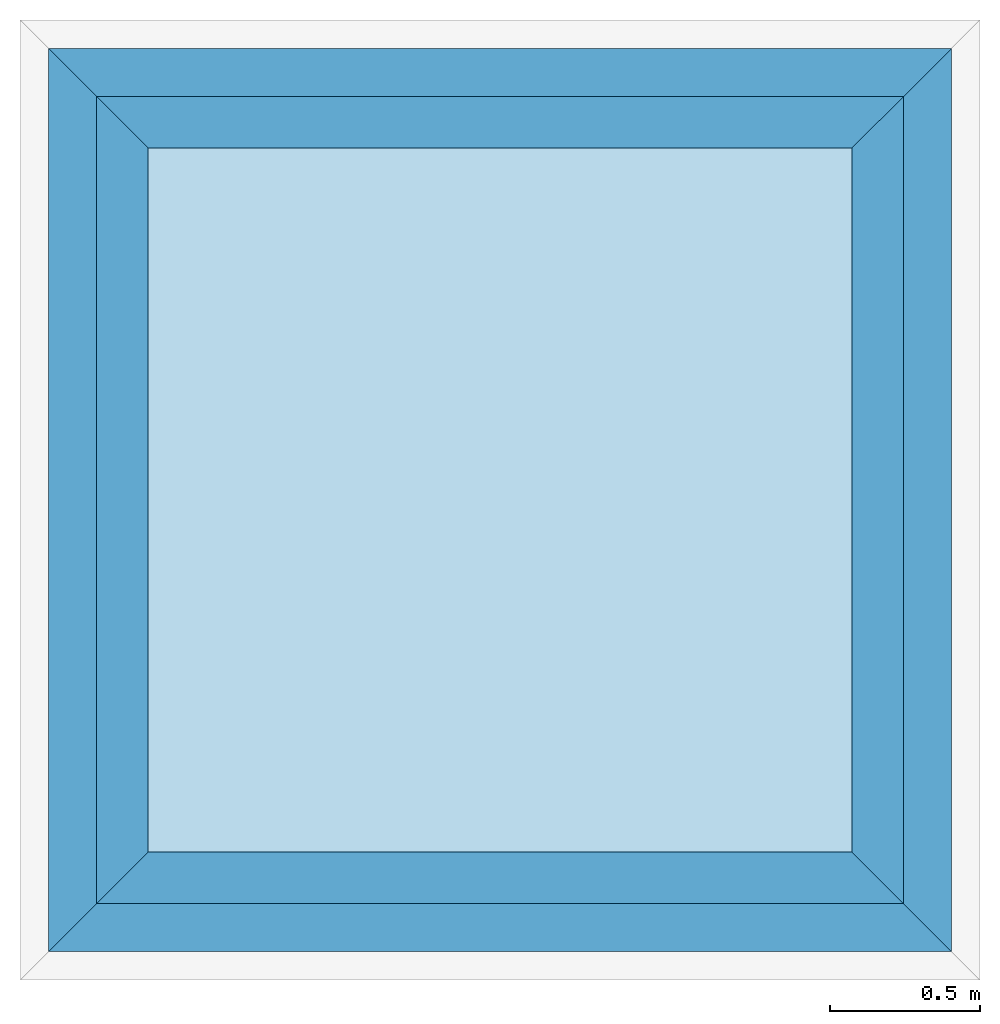
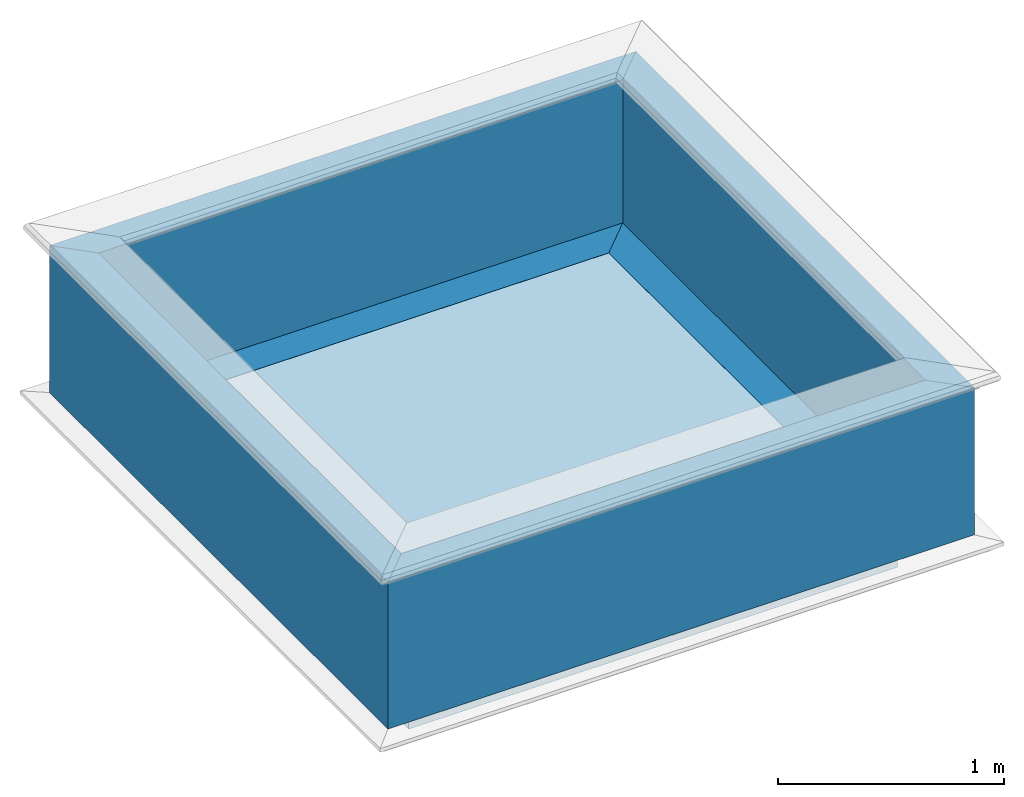
# One storey, part 1 of 2: 4 walls, 1 roof, 2 elements without a shape of their own.
"""IFC4 building model written with IfcOpenShell, lengths in metres."""

from ifc_helpers import new_model, si_unit, frame, origin, origin_with_axes, origin_2d_with_axis, place, context, subcontext, project, library, spatial, polyline, outline, extrude, clip, halfspace, material, layer, layer_set, layer_usage, material_profile, profile_set, profile_usage, type_object, element, aggregate, save


model = new_model("IFC4")

# Units and contexts
model_context = context("Model", 3, precision=1e-05, world=origin_with_axes())
plan_context = context("Plan", 2, precision=1e-05, world=origin_2d_with_axis())
body_context = subcontext(model_context, "Body", "Model", "MODEL_VIEW")
ifc_project = project(units=[si_unit("LENGTHUNIT", "METRE"), si_unit("AREAUNIT", "SQUARE_METRE"), si_unit("VOLUMEUNIT", "CUBIC_METRE"), si_unit("PLANEANGLEUNIT", "RADIAN")], contexts=[model_context, plan_context])
project_library = library(declared=ifc_project)

# Site, building, storey
site = spatial("IfcSite", under=ifc_project)
building = spatial("IfcBuilding", under=site, Name="Cube")
storey_placement = place(None, frame((0.0, 0.0, 2.5), z_axis=(0.0, 0.0, 1.0), x_axis=(1.0, 0.0, 0.0)))
storey = spatial("IfcBuildingStorey", under=building, at=storey_placement, Name="1", CompositionType="ELEMENT", Elevation=2.5)

# Assembly, walls
assembly_1_placement = place(storey_placement, frame((0.0, 0.0, -2.5), z_axis=(0.0, 0.0, 1.0), x_axis=(1.0, 0.0, 0.0)))
assembly_1 = element("IfcElementAssembly", 1, at=assembly_1_placement, inside=storey, Name="parapet")
ifc_material_1 = material(Name="Masonry")
ifc_material_profile = material_profile(ifc_material_1, outline(polyline([(0.25, 0.0), (0.25, 0.795), (0.09, 0.795), (0.09, 0.02), (-0.08, 0.02), (-0.08, 0.0), (0.25, 0.0)])))
ifc_profile_set = profile_set([ifc_material_profile])
ifc_profile_usage_1 = profile_usage(ifc_profile_set)
wall_type = type_object("IfcWallType", Name="parapet", PredefinedType="NOTDEFINED", material=ifc_profile_set)
wall_1_placement = place(assembly_1_placement, frame((-1.0, 2.5, 2.5), z_axis=(1.0, 0.0, 0.0), x_axis=(0.0, 1.0, 0.0)))
wall_1 = element("IfcWall", 2, at=wall_1_placement, type_object=wall_type, material=ifc_profile_usage_1, Name="parapet", context=body_context, shape_type="Clipping", body=[
    clip(clip(extrude(outline(polyline([(0.25, 0.0), (0.25, 0.795), (0.09, 0.795), (0.09, 0.02), (-0.08, 0.02), (-0.08, 0.0), (0.25, 0.0)])), origin_with_axes(), (0.0, 0.0, 1.0), 4.5), halfspace(frame((0.0, -2.5, 1.0), z_axis=(-0.707106781186547, 0.0, -0.707106781186547), x_axis=(0.707106781186547, 0.0, -0.707106781186547)), False)), halfspace(frame((0.0, -2.5, 3.5), z_axis=(-0.707106781186547, 0.0, 0.707106781186547), x_axis=(0.707106781186547, 0.0, 0.707106781186547)), False)),
])
ifc_profile_usage_2 = profile_usage(ifc_profile_set)
wall_2_placement = place(assembly_1_placement, frame((0.0, -1.0, 2.5), z_axis=(0.0, 1.0, 0.0), x_axis=(-1.0, 0.0, 0.0)))
wall_2 = element("IfcWall", 3, at=wall_2_placement, type_object=wall_type, material=ifc_profile_usage_2, Name="parapet", context=body_context, shape_type="Clipping", body=[
    clip(clip(extrude(outline(polyline([(0.25, 0.0), (0.25, 0.795), (0.09, 0.795), (0.09, 0.02), (-0.08, 0.02), (-0.08, 0.0), (0.25, 0.0)])), origin_with_axes(), (0.0, 0.0, 1.0), 4.5), halfspace(frame((0.0, -2.5, 1.0), z_axis=(-0.707106781186547, 0.0, -0.707106781186547), x_axis=(0.707106781186547, 0.0, -0.707106781186547)), False)), halfspace(frame((0.0, -2.5, 3.5), z_axis=(-0.707106781186547, 0.0, 0.707106781186547), x_axis=(0.707106781186547, 0.0, 0.707106781186547)), False)),
])
ifc_profile_usage_3 = profile_usage(ifc_profile_set)
wall_3_placement = place(assembly_1_placement, frame((3.5, 0.0, 2.5), z_axis=(-1.0, 0.0, 0.0), x_axis=(0.0, -1.0, 0.0)))
wall_3 = element("IfcWall", 4, at=wall_3_placement, type_object=wall_type, material=ifc_profile_usage_3, Name="parapet", context=body_context, shape_type="Clipping", body=[
    clip(clip(extrude(outline(polyline([(0.25, 0.0), (0.25, 0.795), (0.09, 0.795), (0.09, 0.02), (-0.08, 0.02), (-0.08, 0.0), (0.25, 0.0)])), origin_with_axes(), (0.0, 0.0, 1.0), 4.5), halfspace(frame((0.0, -2.5, 1.0), z_axis=(-0.707106781186547, 0.0, -0.707106781186547), x_axis=(0.707106781186547, 0.0, -0.707106781186547)), False)), halfspace(frame((0.0, -2.5, 3.5), z_axis=(-0.707106781186547, 0.0, 0.707106781186547), x_axis=(0.707106781186547, 0.0, 0.707106781186547)), False)),
])
ifc_profile_usage_4 = profile_usage(ifc_profile_set)
wall_4_placement = place(assembly_1_placement, frame((2.5, 3.5, 2.5), z_axis=(0.0, -1.0, 0.0), x_axis=(1.0, 0.0, 0.0)))
wall_4 = element("IfcWall", 5, at=wall_4_placement, type_object=wall_type, material=ifc_profile_usage_4, Name="parapet", context=body_context, shape_type="Clipping", body=[
    clip(clip(extrude(outline(polyline([(0.25, 0.0), (0.25, 0.795), (0.09, 0.795), (0.09, 0.02), (-0.08, 0.02), (-0.08, 0.0), (0.25, 0.0)])), origin_with_axes(), (0.0, 0.0, 1.0), 4.5), halfspace(frame((0.0, -2.5, 1.0), z_axis=(-0.707106781186547, 0.0, -0.707106781186547), x_axis=(0.707106781186547, 0.0, -0.707106781186547)), False)), halfspace(frame((0.0, -2.5, 3.5), z_axis=(-0.707106781186547, 0.0, 0.707106781186547), x_axis=(0.707106781186547, 0.0, 0.707106781186547)), False)),
])
aggregate(assembly_1, [wall_1, wall_2, wall_3, wall_4])

# Assembly, roof
assembly_2_placement = place(storey_placement, frame((0.0, 0.0, -2.5), z_axis=(0.0, 0.0, 1.0), x_axis=(1.0, 0.0, 0.0)))
assembly_2 = element("IfcElementAssembly", 6, at=assembly_2_placement, inside=storey, Name="flat-roof")
ifc_material_2 = material(Name="Plaster")
ifc_layer_1 = layer(ifc_material_2, 0.03, Name="Plaster")
ifc_material_3 = material(Name="Insulation")
ifc_layer_2 = layer(ifc_material_3, 0.2, Name="Insulation")
ifc_material_4 = material(Name="Tiles")
ifc_layer_3 = layer(ifc_material_4, 0.03, Name="Tiles")
ifc_layer_set = layer_set([ifc_layer_1, ifc_layer_2, ifc_layer_3], Name="default/flat-roof")
ifc_layer_usage = layer_usage(ifc_layer_set, "AXIS3", "POSITIVE", 0.0)
roof_type = type_object("IfcRoofType", Name="flat-roof", PredefinedType="FLAT_ROOF", material=ifc_layer_set)
roof_placement = place(assembly_2_placement, frame((2.5, 2.5, 2.26), z_axis=(0.0, 0.0, 1.0), x_axis=(1.0, 0.0, 0.0)))
roof = element("IfcRoof", 7, at=roof_placement, type_object=roof_type, material=ifc_layer_usage, Name="flat-roof", context=body_context, shape_type="SweptSolid", body=[
    extrude(outline(polyline([(0.0, 0.0), (-2.5, 0.0), (-2.5, -2.5), (0.0, -2.5), (0.0, 0.0)])), origin(), (0.0, 0.0, 1.0), 0.26),
])
aggregate(assembly_2, [roof])

save(model, "model.ifc")
